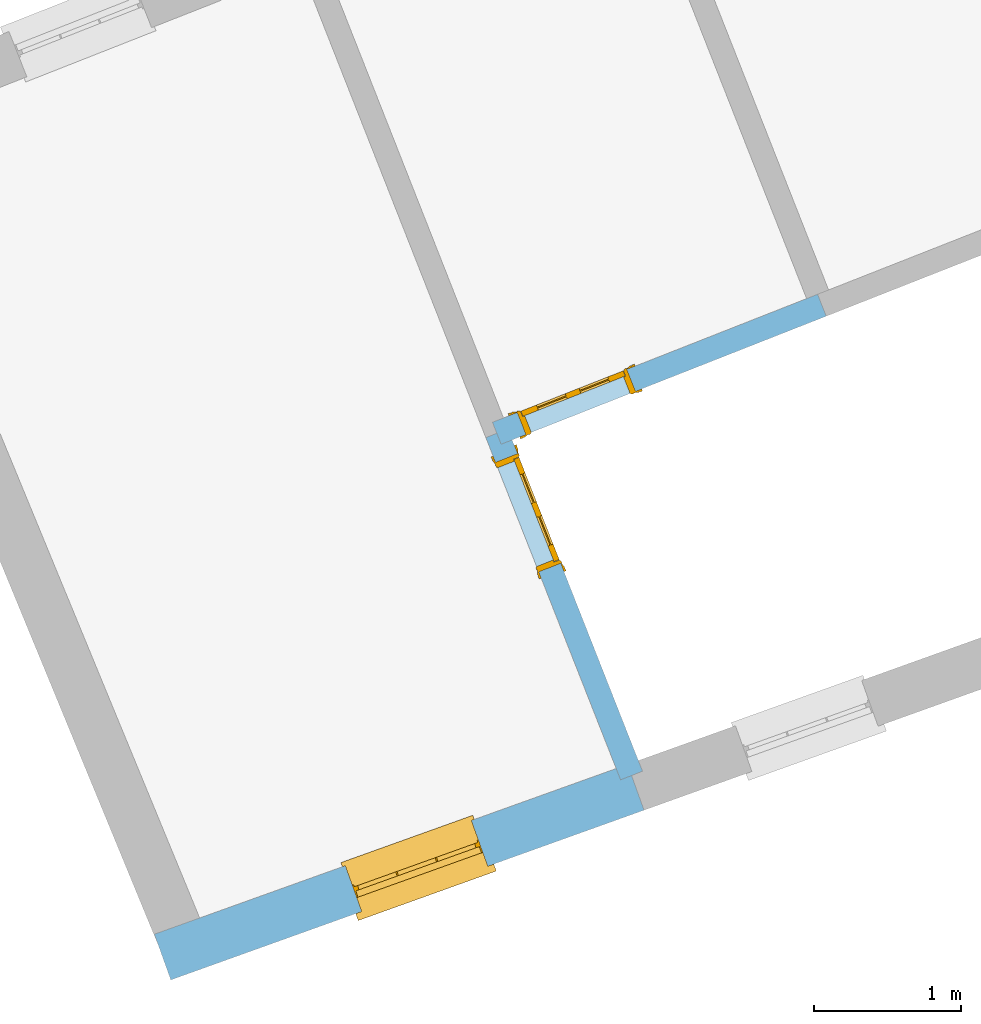
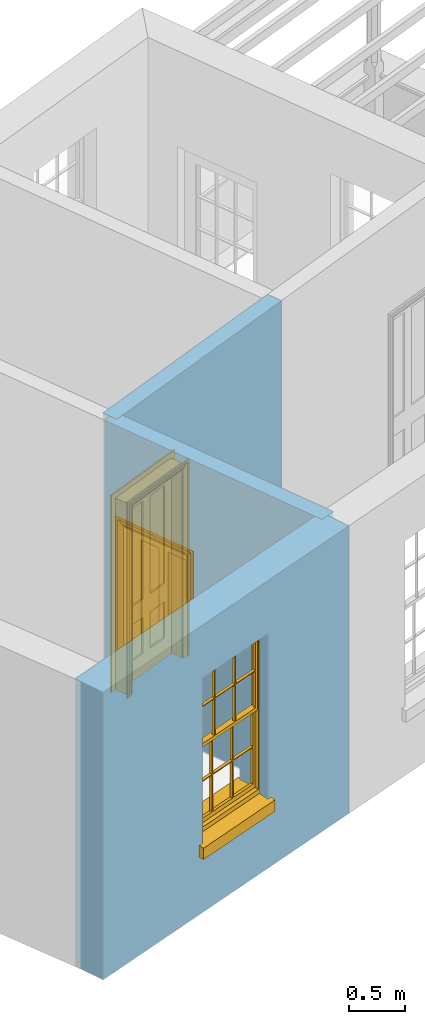
# One storey, part 2 of 8: 2 doors, 1 window, 3 openings, plus 3 elements that do not belong to this part.
"""IFC2X3 building model written with IfcOpenShell, lengths in metres."""

from ifc_helpers import new_model, si_unit, frame, origin, place, context, subcontext, project, spatial, polyline, outline, extrude, faceted_brep, material, layer, layer_set, layer_usage, element, fill, save


model = new_model("IFC2X3")

# Units and contexts
model_context = context("Model", 3, world=origin())
body_context = subcontext(model_context, "Body", "Model", "MODEL_VIEW")
ifc_project = project(units=[si_unit("PLANEANGLEUNIT", "RADIAN"), si_unit("MASSUNIT", "GRAM", prefix="KILO"), si_unit("FORCEUNIT", "NEWTON", prefix="KILO"), si_unit("LENGTHUNIT", "METRE")], contexts=[model_context])

# Site, building, storey
site_placement = place(None, origin())
site = spatial("IfcSite", under=ifc_project, at=site_placement, CompositionType="ELEMENT")
building_placement = place(None, origin())
building = spatial("IfcBuilding", under=site, at=building_placement, Name="Building plot-4", CompositionType="ELEMENT")
storey_placement = place(None, frame((0.0, 0.0, 9.45)))
storey = spatial("IfcBuildingStorey", under=building, at=storey_placement, Name="Floor 2", CompositionType="ELEMENT", Elevation=9.45)

# Wall, opening, window
ifc_material_1 = material(Name="Masonry")
ifc_layer_1 = layer(ifc_material_1, 0.33, ventilated=False)
ifc_layer_set_1 = layer_set([ifc_layer_1], Name="My Wall")
ifc_layer_usage_1 = layer_usage(ifc_layer_set_1, "AXIS2", "NEGATIVE", 0.08)
wall_1_placement = place(storey_placement, origin())
wall_1 = element("IfcWallStandardCase", 1, at=wall_1_placement, inside=storey, material=ifc_layer_usage_1, Name="exterior", context=body_context, shape_type="SweptSolid", body=[
    extrude(outline(polyline([(46.3816931332496, 45.3875319065881), (46.4931346698559, 45.0769183461649), (49.70423854185, 46.2289940933087), (49.5927970052436, 46.539607653732), (46.3816931332496, 45.3875319065881)])), origin(), (0.0, 0.0, 1.0), 3.15),
])
opening_1_placement = place(storey_placement, frame((0.0, 0.0, 0.75)))
opening_1 = element("IfcOpeningElement", 2, at=opening_1_placement, cuts=wall_1, Name="Opening", ObjectType="Opening", context=body_context, shape_type="SweptSolid", body=[
    extrude(outline(polyline([(47.7880730454297, 45.5415146831305), (48.6446134696272, 45.8488231628631), (48.5331719330208, 46.1594367232864), (47.6766315088233, 45.8521282435537), (47.7880730454297, 45.5415146831305)])), origin(), (0.0, 0.0, 1.0), 1.82),
])
window_placement = place(storey_placement, frame((47.7036476389097, 45.7768279864814, 0.75), z_axis=(0.0, 0.0, 1.0), x_axis=(0.856540424197469, 0.307308479732683, 0.0)))
window = element("IfcWindow", 3, at=window_placement, inside=storey, Name="bedroom outside window", OverallHeight=1.82, OverallWidth=0.91, context=body_context, shape_type="Brep", held_by="IfcProductRepresentation", body=[
    faceted_brep([(0.033125, -0.105, 0.975209), (0.01, -0.105, 0.975209), (0.033125, -0.105, 1.376042), (0.876875, -0.105, 0.975209), (0.876875, -0.105, 1.376042), (0.9, -0.105, 0.975209), (0.876875, -0.105, 1.386042), (0.876875, -0.105, 1.786875), (0.9, -0.105, 1.81), (0.033125, -0.105, 1.786875), (0.033125, -0.105, 1.386042), (0.01, -0.105, 1.81), (0.876875, -0.135, 1.376042), (0.876875, -0.135, 0.975209), (0.9, -0.135, 0.937083), (0.033125, -0.135, 1.786875), (0.01, -0.135, 1.81), (0.033125, -0.135, 1.386042), (0.01, -0.135, 0.937083), (0.033125, -0.135, 0.975209), (0.033125, -0.135, 1.376042), (0.876875, -0.135, 1.786875), (0.876875, -0.135, 1.386042), (0.9, -0.135, 1.81), (0.033125, -0.105, 0.937083), (0.01, -0.105, 0.937083), (0.033125, -0.105, 0.53625), (0.876875, -0.105, 0.937083), (0.876875, -0.105, 0.53625), (0.9, -0.105, 0.937083), (0.876875, -0.105, 0.52625), (0.876875, -0.105, 0.125417), (0.9, -0.105, 0.077167), (0.033125, -0.105, 0.125417), (0.033125, -0.105, 0.52625), (0.01, -0.105, 0.077167), (-0.0425, -0.25, 0.01), (-0.0425, -0.3, 0.001667), (0.0, -0.25, 0.01), (0.9525, -0.25, 0.01), (0.91, -0.25, 0.01), (0.9525, -0.3, 0.001667), (-0.02, 0.08, 0.077167), (0.0, 0.08, 0.077167), (-0.02, 0.11, 0.077167), (0.0, -0.06, 0.077167), (0.01, -0.06, 0.077167), (0.91, -0.06, 0.077167), (0.91, 0.08, 0.077167), (0.9, -0.06, 0.077167), (0.93, 0.08, 0.077167), (0.93, 0.11, 0.077167), (0.01, -0.075, 0.975209), (0.9, -0.075, 0.975209), (0.876875, -0.075, 0.125417), (0.876875, -0.075, 0.52625), (0.9, -0.075, 0.077167), (0.876875, -0.075, 0.53625), (0.876875, -0.075, 0.937083), (0.033125, -0.075, 0.125417), (0.01, -0.075, 0.077167), (0.033125, -0.075, 0.52625), (0.033125, -0.075, 0.937083), (0.033125, -0.075, 0.53625), (-0.02, 0.08, 0.052167), (-0.02, 0.11, 0.052167), (0.93, 0.11, 0.052167), (0.93, 0.08, 0.052167), (0.91, 0.08, 0.052167), (0.0, 0.08, 0.052167), (0.91, -0.15, 0.026667), (0.0, -0.15, 0.026667), (-0.0425, -0.3, -0.123333), (0.9525, -0.3, -0.123333), (-0.0425, -0.25, -0.123333), (0.9525, -0.25, -0.123333), (0.01, -0.06, 1.81), (0.9, -0.06, 1.81), (0.0, -0.06, 1.82), (0.91, -0.06, 1.82), (0.01, -0.15, 0.077167), (0.9, -0.15, 0.077167), (0.592292, -0.105, 0.125417), (0.592292, -0.075, 0.125417), (0.317708, -0.075, 0.125417), (0.317708, -0.105, 0.125417), (0.592292, -0.105, 0.53625), (0.317708, -0.105, 0.53625), (0.317708, -0.105, 0.52625), (0.592292, -0.105, 0.52625), (0.592292, -0.075, 0.53625), (0.317708, -0.075, 0.53625), (0.592292, -0.135, 1.386042), (0.592292, -0.105, 1.386042), (0.317708, -0.105, 1.386042), (0.317708, -0.135, 1.386042), (0.317708, -0.135, 1.376042), (0.592292, -0.135, 1.376042), (0.317708, -0.105, 1.376042), (0.592292, -0.105, 1.376042), (0.602292, -0.135, 1.376042), (0.592292, -0.135, 0.975209), (0.602292, -0.135, 0.975209), (0.602292, -0.105, 0.975209), (0.592292, -0.105, 0.975209), (0.602292, -0.105, 1.376042), (0.602292, -0.075, 0.53625), (0.602292, -0.105, 0.53625), (0.317708, -0.075, 0.52625), (0.307708, -0.075, 0.125417), (0.307708, -0.075, 0.52625), (0.602292, -0.075, 0.52625), (0.602292, -0.075, 0.125417), (0.592292, -0.075, 0.52625), (0.307708, -0.075, 0.53625), (0.317708, -0.075, 0.937083), (0.307708, -0.075, 0.937083), (0.602292, -0.075, 0.937083), (0.592292, -0.075, 0.937083), (0.307708, -0.105, 0.52625), (0.307708, -0.105, 0.125417), (0.307708, -0.105, 0.53625), (0.307708, -0.105, 0.937083), (0.592292, -0.105, 0.937083), (0.317708, -0.105, 0.937083), (0.602292, -0.105, 0.937083), (0.602292, -0.105, 0.52625), (0.602292, -0.105, 0.125417), (0.307708, -0.135, 1.386042), (0.307708, -0.135, 1.376042), (0.307708, -0.135, 0.975209), (0.317708, -0.135, 0.975209), (0.317708, -0.135, 1.786875), (0.307708, -0.135, 1.786875), (0.602292, -0.135, 1.786875), (0.592292, -0.135, 1.786875), (0.602292, -0.135, 1.386042), (0.602292, -0.105, 1.386042), (0.307708, -0.105, 1.386042), (0.307708, -0.105, 1.786875), (0.317708, -0.105, 1.786875), (0.592292, -0.105, 1.786875), (0.602292, -0.105, 1.786875), (0.307708, -0.105, 1.376042), (0.317708, -0.105, 0.975209), (0.307708, -0.105, 0.975209), (0.91, -0.15, 1.82), (0.9, -0.15, 1.81), (0.01, -0.15, 1.81), (0.0, -0.15, 1.82), (0.91, -0.25, 0.0), (0.0, -0.25, 0.0), (0.91, 0.08, 0.0), (0.0, 0.08, 0.0)], [[[0, 1, 2]], [[3, 4, 5]], [[6, 7, 8]], [[9, 10, 11]], [[12, 13, 14]], [[15, 16, 17]], [[18, 19, 20]], [[21, 22, 23]], [[24, 25, 26]], [[27, 28, 29]], [[30, 31, 32]], [[33, 34, 35]], [[14, 27, 29]], [[25, 24, 18]], [[36, 37, 38]], [[39, 40, 41]], [[42, 43, 44]], [[45, 46, 43]], [[47, 48, 49]], [[50, 51, 48]], [[1, 0, 52]], [[5, 53, 3]], [[54, 55, 56]], [[57, 58, 53]], [[59, 60, 61]], [[62, 63, 52]], [[48, 43, 46, 49]], [[51, 44, 43, 48]], [[64, 42, 44, 65]], [[65, 44, 51, 66]], [[66, 51, 50, 67]], [[65, 66, 68, 69]], [[60, 56, 49, 46]], [[70, 71, 38, 40]], [[37, 41, 40, 38]], [[37, 72, 73, 41]], [[74, 75, 73, 72]], [[8, 11, 76, 77]], [[76, 78, 79, 77]], [[32, 35, 80, 81]], [[81, 80, 71, 70]], [[82, 83, 84, 85]], [[86, 87, 88, 89]], [[86, 90, 91, 87]], [[92, 93, 94, 95]], [[92, 95, 96, 97]], [[96, 98, 99, 97]], [[100, 97, 101, 102]], [[103, 104, 99, 105]], [[97, 99, 104, 101]], [[102, 103, 105, 100]], [[28, 57, 106, 107]], [[108, 84, 109, 110]], [[111, 112, 83, 113]], [[114, 110, 61, 63]], [[90, 113, 108, 91]], [[115, 91, 114, 116]], [[117, 106, 90, 118]], [[111, 106, 57, 55]], [[119, 110, 109, 120]], [[34, 61, 110, 119]], [[89, 113, 83, 82]], [[88, 108, 113, 89]], [[85, 84, 108, 88]], [[121, 114, 63, 26]], [[122, 116, 114, 121]], [[123, 118, 90, 86]], [[87, 91, 115, 124]], [[107, 106, 117, 125]], [[126, 111, 55, 30]], [[127, 112, 111, 126]], [[126, 30, 28, 107]], [[88, 119, 120, 85]], [[126, 89, 82, 127]], [[125, 123, 86, 107]], [[121, 26, 34, 119]], [[124, 122, 121, 87]], [[128, 17, 20, 129]], [[96, 129, 130, 131]], [[132, 133, 128, 95]], [[134, 135, 92, 136]], [[100, 12, 22, 136]], [[137, 6, 4, 105]], [[94, 138, 139, 140]], [[137, 93, 141, 142]], [[99, 98, 94, 93]], [[143, 2, 10, 138]], [[144, 145, 143, 98]], [[129, 143, 145, 130]], [[20, 2, 143, 129]], [[131, 144, 98, 96]], [[128, 138, 10, 17]], [[133, 139, 138, 128]], [[135, 141, 93, 92]], [[95, 94, 140, 132]], [[22, 6, 137, 136]], [[136, 137, 142, 134]], [[100, 105, 4, 12]], [[107, 86, 89, 126]], [[106, 111, 113, 90]], [[91, 108, 110, 114]], [[87, 121, 119, 88]], [[97, 100, 136, 92]], [[129, 96, 95, 128]], [[98, 143, 138, 94]], [[105, 99, 93, 137]], [[131, 101, 104, 144]], [[124, 115, 118, 123]], [[132, 140, 141, 135]], [[120, 109, 59, 33]], [[15, 9, 139, 133]], [[134, 142, 7, 21]], [[31, 54, 112, 127]], [[36, 74, 72, 37]], [[39, 41, 73, 75]], [[18, 14, 101, 131]], [[23, 16, 132, 135]], [[83, 56, 60, 84]], [[52, 53, 118, 115]], [[53, 52, 144, 104]], [[11, 8, 141, 140]], [[14, 18, 124, 123]], [[2, 1, 11, 10]], [[8, 5, 4, 6]], [[57, 53, 56, 55]], [[60, 52, 63, 61]], [[26, 25, 35, 34]], [[32, 29, 28, 30]], [[14, 23, 22, 12]], [[18, 20, 17, 16]], [[19, 0, 2, 20]], [[17, 10, 9, 15]], [[12, 4, 3, 13]], [[21, 7, 6, 22]], [[27, 58, 57, 28]], [[30, 55, 54, 31]], [[33, 59, 61, 34]], [[26, 63, 62, 24]], [[5, 8, 77, 53]], [[76, 11, 1, 52]], [[46, 45, 78, 76]], [[49, 77, 79, 47]], [[70, 146, 147, 81]], [[71, 80, 148, 149]], [[19, 130, 145, 0]], [[102, 13, 3, 103]], [[116, 122, 24, 62]], [[29, 32, 81, 14]], [[80, 35, 25, 18]], [[60, 46, 76, 52]], [[77, 49, 56, 53]], [[23, 14, 81, 147]], [[16, 148, 80, 18]], [[35, 85, 120]], [[120, 33, 35]], [[127, 82, 32]], [[32, 31, 127]], [[32, 82, 85, 35]], [[102, 101, 14]], [[14, 13, 102]], [[18, 131, 130]], [[130, 19, 18]], [[134, 21, 23]], [[23, 135, 134]], [[16, 15, 133]], [[133, 132, 16]], [[11, 140, 139]], [[139, 9, 11]], [[142, 141, 8]], [[8, 7, 142]], [[23, 147, 148, 16]], [[146, 149, 148, 147]], [[52, 115, 116]], [[116, 62, 52]], [[118, 53, 117]], [[58, 117, 53]], [[27, 125, 117, 58]], [[56, 83, 112]], [[112, 54, 56]], [[109, 84, 60]], [[60, 59, 109]], [[125, 27, 14]], [[14, 123, 125]], [[122, 124, 18]], [[18, 24, 122]], [[145, 144, 52]], [[52, 0, 145]], [[103, 3, 53]], [[53, 104, 103]], [[79, 78, 149, 146]], [[78, 45, 71, 149]], [[146, 70, 47, 79]], [[150, 75, 74, 151]], [[68, 66, 67]], [[48, 68, 67, 50]], [[69, 64, 65]], [[42, 64, 69, 43]], [[69, 68, 152, 153]], [[70, 68, 48, 47]], [[150, 152, 68, 70]], [[43, 69, 71, 45]], [[69, 153, 151, 71]], [[152, 150, 151, 153]], [[38, 151, 74, 36]], [[71, 151, 38]], [[39, 75, 150, 40]], [[40, 150, 70]]]),
])
fill(opening_1, window)

# Wall, opening, door
ifc_material_2 = material(Name="Masonry")
ifc_layer_2 = layer(ifc_material_2, 0.16, ventilated=False)
ifc_layer_set_2 = layer_set([ifc_layer_2], Name="My Wall")
ifc_layer_usage_2 = layer_usage(ifc_layer_set_2, "AXIS2", "NEGATIVE", 0.08)
wall_2_placement = place(storey_placement, origin())
wall_2 = element("IfcWallStandardCase", 4, at=wall_2_placement, inside=storey, material=ifc_layer_usage_2, Name="interior", context=body_context, shape_type="SweptSolid", body=[
    extrude(outline(polyline([(48.675963659778, 48.860958817468), (48.7345922073266, 48.7120874185616), (50.9405049863652, 49.5808201852595), (50.8818764388166, 49.7296915841659), (48.675963659778, 48.860958817468)])), origin(), (0.0, 0.0, 1.0), 3.15),
])
opening_2_placement = place(storey_placement, frame((0.0, 0.0, 0.0199999999999996)))
opening_2 = element("IfcOpeningElement", 5, at=opening_2_placement, cuts=wall_2, Name="Opening", ObjectType="Opening", context=body_context, shape_type="SweptSolid", body=[
    extrude(outline(polyline([(48.9020725310963, 48.7780445345539), (49.646429525628, 49.0711872722973), (49.5878009780793, 49.2200586712036), (48.8434439835476, 48.9269159334602), (48.9020725310963, 48.7780445345539)])), origin(), (0.0, 0.0, 1.0), 2.1),
])
door_1_placement = place(storey_placement, frame((48.8727582573219, 48.8524802340071, 0.0199999999999996), z_axis=(0.0, 0.0, 1.0), x_axis=(0.744356994531735, 0.293142737743381, 0.0)))
door_1 = element("IfcDoor", 6, at=door_1_placement, inside=storey, Name="toilet inside door", OverallHeight=2.1, OverallWidth=0.8, context=body_context, shape_type="Brep", held_by="IfcProductRepresentation", body=[
    faceted_brep([(0.773, 0.08, 1.895), (0.66, 0.08, 1.895), (0.66, 0.08, 2.073), (0.773, 0.08, 2.073), (0.773, 0.08, 0.82), (0.66, 0.08, 0.82), (0.45, 0.08, 1.895), (0.45, 0.08, 2.073), (0.773, 0.08, 0.62), (0.66, 0.08, 0.62), (0.66, 0.065, 0.82), (0.66, 0.065, 1.895), (0.45, 0.065, 1.895), (0.35, 0.08, 1.895), (0.35, 0.08, 2.073), (0.773, 0.08, 0.225), (0.66, 0.08, 0.225), (0.45, 0.08, 0.62), (0.45, 0.08, 0.82), (0.45, 0.065, 0.82), (0.35, 0.08, 0.82), (0.14, 0.08, 2.073), (0.14, 0.08, 1.895), (0.773, 0.08, 0.0), (0.66, 0.08, 0.0), (0.66, 0.065, 0.225), (0.66, 0.065, 0.62), (0.45, 0.065, 0.62), (0.35, 0.08, 0.62), (0.35, 0.065, 0.82), (0.35, 0.065, 1.895), (0.14, 0.065, 1.895), (0.027, 0.08, 2.073), (0.027, 0.08, 1.895), (0.773, 0.042, 0.0), (0.66, 0.042, 0.0), (0.45, 0.08, 0.0), (0.45, 0.08, 0.225), (0.45, 0.065, 0.225), (0.35, 0.08, 0.225), (0.14, 0.08, 0.82), (0.14, 0.08, 0.62), (0.14, 0.065, 0.82), (0.027, 0.08, 0.82), (0.773, 0.042, 0.225), (0.66, 0.042, 0.225), (0.45, 0.042, 0.0), (0.35, 0.08, 0.0), (0.35, 0.065, 0.225), (0.35, 0.065, 0.62), (0.14, 0.065, 0.62), (0.027, 0.08, 0.62), (0.773, 0.042, 0.62), (0.66, 0.042, 0.62), (0.45, 0.042, 0.225), (0.35, 0.042, 0.0), (0.14, 0.08, 0.225), (0.14, 0.08, 0.0), (0.14, 0.065, 0.225), (0.027, 0.08, 0.225), (0.773, 0.042, 0.82), (0.66, 0.042, 0.82), (0.66, 0.057, 0.62), (0.66, 0.057, 0.225), (0.45, 0.057, 0.225), (0.35, 0.042, 0.225), (0.14, 0.042, 0.0), (0.027, 0.08, 0.0), (0.773, 0.042, 1.895), (0.66, 0.042, 1.895), (0.45, 0.042, 0.62), (0.45, 0.042, 0.82), (0.45, 0.057, 0.62), (0.35, 0.042, 0.62), (0.14, 0.042, 0.225), (0.027, 0.042, 0.0), (0.773, 0.042, 2.073), (0.66, 0.042, 2.073), (0.66, 0.057, 1.895), (0.66, 0.057, 0.82), (0.45, 0.057, 0.82), (0.35, 0.042, 0.82), (0.35, 0.057, 0.62), (0.35, 0.057, 0.225), (0.14, 0.057, 0.225), (0.027, 0.042, 0.225), (0.45, 0.042, 1.895), (0.45, 0.042, 2.073), (0.45, 0.057, 1.895), (0.35, 0.042, 1.895), (0.14, 0.042, 0.82), (0.14, 0.042, 0.62), (0.14, 0.057, 0.62), (0.027, 0.042, 0.62), (0.35, 0.042, 2.073), (0.35, 0.057, 1.895), (0.35, 0.057, 0.82), (0.14, 0.057, 0.82), (0.027, 0.042, 0.82), (0.14, 0.042, 2.073), (0.14, 0.042, 1.895), (0.14, 0.057, 1.895), (0.027, 0.042, 1.895), (0.027, 0.042, 2.073), (0.02, 0.085, 0.0), (0.005, 0.09, 0.0), (0.005, 0.09, 2.095), (0.02, 0.085, 2.08), (0.02, 0.08, 0.0), (0.0, 0.085, 0.0), (0.0, 0.085, 2.1), (0.795, 0.09, 2.095), (0.78, 0.085, 2.08), (0.02, 0.08, 2.08), (0.0, 0.08, 0.0), (-0.032, 0.095, 0.0), (-0.032, 0.095, 2.132), (0.8, 0.085, 2.1), (0.795, 0.09, 0.0), (0.78, 0.085, 0.0), (0.78, 0.08, 2.08), (0.04, 0.04, 0.0), (0.025, 0.04, 0.0), (0.025, 0.04, 2.075), (0.04, 0.04, 2.06), (-0.04, 0.09, 0.0), (-0.04, 0.09, 2.14), (0.832, 0.095, 2.132), (0.8, 0.085, 0.0), (0.78, 0.08, 0.0), (0.8, 0.08, 0.0), (0.86, 0.08, 0.0), (0.86, 0.08, 2.16), (0.8, 0.08, 2.1), (-0.06, 0.08, 2.16), (0.0, 0.08, 2.1), (-0.06, 0.08, 0.0), (-0.04, 0.095, 0.0), (-0.04, 0.095, 2.14), (0.84, 0.09, 2.14), (0.832, 0.095, 0.0), (0.84, 0.09, 0.0), (0.86, 0.095, 0.0), (0.86, 0.095, 2.16), (-0.06, 0.095, 2.16), (-0.06, 0.095, 0.0), (0.84, 0.095, 0.0), (0.84, 0.095, 2.14), (-0.025, -0.095, 0.0), (-0.025, -0.09, 0.0), (-0.025, -0.09, 2.125), (-0.025, -0.095, 2.125), (-0.017, -0.095, 0.0), (-0.017, -0.095, 2.117), (0.825, -0.09, 2.125), (0.825, -0.095, 2.125), (0.825, -0.095, 0.0), (0.845, -0.095, 0.0), (-0.045, -0.095, 2.145), (-0.045, -0.095, 0.0), (0.845, -0.095, 2.145), (0.015, -0.085, 0.0), (0.015, -0.085, 2.085), (0.817, -0.095, 2.117), (0.825, -0.09, 0.0), (0.845, -0.08, 0.0), (0.845, -0.08, 2.145), (-0.045, -0.08, 2.145), (-0.045, -0.08, 0.0), (0.02, -0.09, 0.0), (0.02, -0.09, 2.08), (0.785, -0.085, 2.085), (0.817, -0.095, 0.0), (0.8, -0.08, 0.0), (0.8, -0.08, 2.1), (0.0, -0.08, 2.1), (0.0, -0.08, 0.0), (0.035, -0.085, 0.0), (0.035, -0.085, 2.065), (0.78, -0.09, 2.08), (0.785, -0.085, 0.0), (0.775, 0.04, 2.075), (0.76, 0.04, 2.06), (0.035, -0.08, 2.065), (0.035, -0.08, 0.0), (0.765, -0.085, 2.065), (0.78, -0.09, 0.0), (0.765, -0.08, 0.0), (0.765, -0.08, 2.065), (0.765, -0.085, 0.0), (0.04, -0.08, 2.06), (0.04, -0.08, 0.0), (0.76, -0.08, 2.06), (0.76, -0.08, 0.0), (0.76, 0.04, 0.0), (0.775, 0.04, 0.0), (0.025, 0.08, 0.0), (0.025, 0.08, 2.075), (0.775, 0.08, 0.0), (0.775, 0.08, 2.075)], [[[0, 1, 2, 3]], [[1, 0, 4, 5]], [[1, 6, 7, 2]], [[8, 9, 5, 4]], [[1, 5, 10, 11]], [[6, 1, 11, 12]], [[6, 13, 14, 7]], [[15, 16, 9, 8]], [[9, 17, 18, 5]], [[5, 18, 19, 10]], [[10, 19, 12, 11]], [[18, 6, 12, 19]], [[18, 20, 13, 6]], [[21, 14, 13, 22]], [[23, 24, 16, 15]], [[9, 16, 25, 26]], [[17, 9, 26, 27]], [[17, 28, 20, 18]], [[13, 20, 29, 30]], [[22, 13, 30, 31]], [[32, 21, 22, 33]], [[34, 35, 24, 23]], [[24, 36, 37, 16]], [[16, 37, 38, 25]], [[25, 38, 27, 26]], [[37, 17, 27, 38]], [[37, 39, 28, 17]], [[40, 20, 28, 41]], [[20, 40, 42, 29]], [[31, 30, 29, 42]], [[40, 22, 31, 42]], [[33, 22, 40, 43]], [[35, 34, 44, 45]], [[35, 46, 36, 24]], [[36, 47, 39, 37]], [[28, 39, 48, 49]], [[41, 28, 49, 50]], [[43, 40, 41, 51]], [[45, 44, 52, 53]], [[46, 35, 45, 54]], [[46, 55, 47, 36]], [[56, 39, 47, 57]], [[39, 56, 58, 48]], [[50, 49, 48, 58]], [[56, 41, 50, 58]], [[51, 41, 56, 59]], [[53, 52, 60, 61]], [[45, 53, 62, 63]], [[54, 45, 63, 64]], [[55, 46, 54, 65]], [[55, 66, 57, 47]], [[59, 56, 57, 67]], [[61, 60, 68, 69]], [[70, 53, 61, 71]], [[53, 70, 72, 62]], [[72, 64, 63, 62]], [[70, 54, 64, 72]], [[65, 54, 70, 73]], [[65, 74, 66, 55]], [[67, 57, 66, 75]], [[69, 68, 76, 77]], [[61, 69, 78, 79]], [[71, 61, 79, 80]], [[73, 70, 71, 81]], [[65, 73, 82, 83]], [[74, 65, 83, 84]], [[74, 85, 75, 66]], [[86, 69, 77, 87]], [[69, 86, 88, 78]], [[88, 80, 79, 78]], [[86, 71, 80, 88]], [[81, 71, 86, 89]], [[73, 81, 90, 91]], [[73, 91, 92, 82]], [[83, 82, 92, 84]], [[91, 74, 84, 92]], [[91, 93, 85, 74]], [[89, 86, 87, 94]], [[81, 89, 95, 96]], [[90, 81, 96, 97]], [[90, 98, 93, 91]], [[94, 99, 100, 89]], [[89, 100, 101, 95]], [[101, 97, 96, 95]], [[100, 90, 97, 101]], [[100, 102, 98, 90]], [[99, 103, 102, 100]], [[32, 103, 99, 21]], [[102, 103, 32, 33]], [[98, 102, 33, 43]], [[21, 99, 94, 14]], [[94, 87, 7, 14]], [[7, 87, 77, 2]], [[76, 3, 2, 77]], [[43, 51, 93, 98]], [[51, 59, 85, 93]], [[67, 75, 85, 59]], [[34, 23, 15, 44]], [[44, 15, 8, 52]], [[52, 8, 4, 60]], [[0, 68, 60, 4]], [[0, 3, 76, 68]], [[104, 105, 106, 107]], [[104, 108, 109, 105]], [[105, 109, 110, 106]], [[107, 106, 111, 112]], [[107, 113, 108, 104]], [[114, 109, 108]], [[109, 115, 116, 110]], [[106, 110, 117, 111]], [[112, 111, 118, 119]], [[113, 107, 112, 120]], [[121, 122, 123, 124]], [[115, 109, 114, 125]], [[115, 125, 126, 116]], [[110, 116, 127, 117]], [[111, 117, 128, 118]], [[118, 128, 129, 119]], [[120, 112, 119, 129]], [[130, 129, 128]], [[130, 131, 132, 133]], [[133, 132, 134, 135]], [[135, 134, 136, 114]], [[136, 125, 114]], [[125, 137, 138, 126]], [[116, 126, 139, 127]], [[117, 127, 140, 128]], [[141, 130, 128, 140]], [[131, 130, 141]], [[131, 142, 143, 132]], [[132, 143, 144, 134]], [[134, 144, 145, 136]], [[137, 125, 136, 145]], [[143, 142, 146]], [[143, 146, 147]], [[137, 145, 144]], [[143, 147, 138]], [[138, 137, 144]], [[143, 138, 144]], [[126, 138, 147, 139]], [[127, 139, 141, 140]], [[142, 131, 141, 146]], [[139, 147, 146, 141]], [[148, 149, 150, 151]], [[149, 152, 153, 150]], [[151, 150, 154, 155]], [[155, 156, 157]], [[158, 159, 148]], [[158, 148, 151]], [[155, 157, 160]], [[158, 151, 155]], [[155, 160, 158]], [[152, 161, 162, 153]], [[150, 153, 163, 154]], [[155, 154, 164, 156]], [[156, 164, 165, 157]], [[157, 165, 166, 160]], [[160, 166, 167, 158]], [[158, 167, 168, 159]], [[161, 169, 170, 162]], [[153, 162, 171, 163]], [[154, 163, 172, 164]], [[165, 164, 173]], [[165, 173, 174, 166]], [[166, 174, 175, 167]], [[167, 175, 176, 168]], [[169, 177, 178, 170]], [[162, 170, 179, 171]], [[163, 171, 180, 172]], [[172, 180, 173, 164]], [[124, 123, 181, 182]], [[183, 178, 177, 184]], [[170, 178, 185, 179]], [[171, 179, 186, 180]], [[187, 173, 180]], [[185, 188, 187, 189]], [[188, 185, 178, 183]], [[179, 185, 189, 186]], [[189, 187, 180, 186]], [[190, 183, 184, 191]], [[192, 188, 183, 190]], [[191, 184, 122, 121]], [[124, 190, 191, 121]], [[193, 187, 188, 192]], [[182, 192, 190, 124]], [[184, 176, 122]], [[194, 195, 187, 193]], [[192, 182, 194, 193]], [[161, 176, 184]], [[114, 108, 122, 176]], [[173, 187, 195]], [[152, 149, 176, 161]], [[169, 161, 184, 177]], [[196, 122, 108]], [[176, 175, 135, 114]], [[173, 195, 129, 130]], [[176, 149, 168]], [[123, 122, 196, 197]], [[196, 108, 113, 197]], [[175, 174, 133, 135]], [[198, 129, 195]], [[133, 174, 173, 130]], [[159, 168, 149, 148]], [[181, 123, 197, 199]], [[197, 113, 120, 199]], [[199, 120, 129, 198]], [[195, 181, 199, 198]], [[195, 194, 182, 181]]]),
])
fill(opening_2, door_1)

wall_3_placement = place(storey_placement, origin())
wall_3 = element("IfcWallStandardCase", 7, at=wall_3_placement, inside=storey, material=ifc_layer_usage_2, Name="interior", context=body_context, shape_type="SweptSolid", body=[
    extrude(outline(polyline([(48.7797136330055, 48.8158373917891), (48.6308422340991, 48.7572088442405), (49.5453774358768, 46.4349931228854), (49.6942488347832, 46.493621670434), (48.7797136330055, 48.8158373917891)])), origin(), (0.0, 0.0, 1.0), 3.15),
])
opening_3_placement = place(storey_placement, frame((0.0, 0.0, 0.0199999999999996)))
opening_3 = element("IfcOpeningElement", 8, at=opening_3_placement, cuts=wall_3, Name="Opening", ObjectType="Opening", context=body_context, shape_type="SweptSolid", body=[
    extrude(outline(polyline([(48.6967993500914, 48.5897285204708), (48.9899420878348, 47.8453715259391), (49.1388134867411, 47.9040000734878), (48.8456707489977, 48.6483570680195), (48.6967993500914, 48.5897285204708)])), origin(), (0.0, 0.0, 1.0), 2.1),
])
door_2_placement = place(storey_placement, frame((48.7712350495446, 48.6190427942452, 0.0199999999999996), z_axis=(0.0, 0.0, 1.0), x_axis=(0.293142737743374, -0.744356994531742, 0.0)))
door_2 = element("IfcDoor", 9, at=door_2_placement, inside=storey, Name="bedroom inside door", OverallHeight=2.1, OverallWidth=0.8, context=body_context, shape_type="Brep", held_by="IfcProductRepresentation", body=[
    faceted_brep([(0.773, 0.08, 1.895), (0.66, 0.08, 1.895), (0.66, 0.08, 2.073), (0.773, 0.08, 2.073), (0.773, 0.08, 0.82), (0.66, 0.08, 0.82), (0.45, 0.08, 1.895), (0.45, 0.08, 2.073), (0.773, 0.08, 0.62), (0.66, 0.08, 0.62), (0.66, 0.065, 0.82), (0.66, 0.065, 1.895), (0.45, 0.065, 1.895), (0.35, 0.08, 1.895), (0.35, 0.08, 2.073), (0.773, 0.08, 0.225), (0.66, 0.08, 0.225), (0.45, 0.08, 0.62), (0.45, 0.08, 0.82), (0.45, 0.065, 0.82), (0.35, 0.08, 0.82), (0.14, 0.08, 2.073), (0.14, 0.08, 1.895), (0.773, 0.08, 0.0), (0.66, 0.08, 0.0), (0.66, 0.065, 0.225), (0.66, 0.065, 0.62), (0.45, 0.065, 0.62), (0.35, 0.08, 0.62), (0.35, 0.065, 0.82), (0.35, 0.065, 1.895), (0.14, 0.065, 1.895), (0.027, 0.08, 2.073), (0.027, 0.08, 1.895), (0.773, 0.042, 0.0), (0.66, 0.042, 0.0), (0.45, 0.08, 0.0), (0.45, 0.08, 0.225), (0.45, 0.065, 0.225), (0.35, 0.08, 0.225), (0.14, 0.08, 0.82), (0.14, 0.08, 0.62), (0.14, 0.065, 0.82), (0.027, 0.08, 0.82), (0.773, 0.042, 0.225), (0.66, 0.042, 0.225), (0.45, 0.042, 0.0), (0.35, 0.08, 0.0), (0.35, 0.065, 0.225), (0.35, 0.065, 0.62), (0.14, 0.065, 0.62), (0.027, 0.08, 0.62), (0.773, 0.042, 0.62), (0.66, 0.042, 0.62), (0.45, 0.042, 0.225), (0.35, 0.042, 0.0), (0.14, 0.08, 0.225), (0.14, 0.08, 0.0), (0.14, 0.065, 0.225), (0.027, 0.08, 0.225), (0.773, 0.042, 0.82), (0.66, 0.042, 0.82), (0.66, 0.057, 0.62), (0.66, 0.057, 0.225), (0.45, 0.057, 0.225), (0.35, 0.042, 0.225), (0.14, 0.042, 0.0), (0.027, 0.08, 0.0), (0.773, 0.042, 1.895), (0.66, 0.042, 1.895), (0.45, 0.042, 0.62), (0.45, 0.042, 0.82), (0.45, 0.057, 0.62), (0.35, 0.042, 0.62), (0.14, 0.042, 0.225), (0.027, 0.042, 0.0), (0.773, 0.042, 2.073), (0.66, 0.042, 2.073), (0.66, 0.057, 1.895), (0.66, 0.057, 0.82), (0.45, 0.057, 0.82), (0.35, 0.042, 0.82), (0.35, 0.057, 0.62), (0.35, 0.057, 0.225), (0.14, 0.057, 0.225), (0.027, 0.042, 0.225), (0.45, 0.042, 1.895), (0.45, 0.042, 2.073), (0.45, 0.057, 1.895), (0.35, 0.042, 1.895), (0.14, 0.042, 0.82), (0.14, 0.042, 0.62), (0.14, 0.057, 0.62), (0.027, 0.042, 0.62), (0.35, 0.042, 2.073), (0.35, 0.057, 1.895), (0.35, 0.057, 0.82), (0.14, 0.057, 0.82), (0.027, 0.042, 0.82), (0.14, 0.042, 2.073), (0.14, 0.042, 1.895), (0.14, 0.057, 1.895), (0.027, 0.042, 1.895), (0.027, 0.042, 2.073), (0.02, 0.085, 0.0), (0.005, 0.09, 0.0), (0.005, 0.09, 2.095), (0.02, 0.085, 2.08), (0.02, 0.08, 0.0), (0.0, 0.085, 0.0), (0.0, 0.085, 2.1), (0.795, 0.09, 2.095), (0.78, 0.085, 2.08), (0.02, 0.08, 2.08), (0.0, 0.08, 0.0), (-0.032, 0.095, 0.0), (-0.032, 0.095, 2.132), (0.8, 0.085, 2.1), (0.795, 0.09, 0.0), (0.78, 0.085, 0.0), (0.78, 0.08, 2.08), (0.04, 0.04, 0.0), (0.025, 0.04, 0.0), (0.025, 0.04, 2.075), (0.04, 0.04, 2.06), (-0.04, 0.09, 0.0), (-0.04, 0.09, 2.14), (0.832, 0.095, 2.132), (0.8, 0.085, 0.0), (0.78, 0.08, 0.0), (0.8, 0.08, 0.0), (0.86, 0.08, 0.0), (0.86, 0.08, 2.16), (0.8, 0.08, 2.1), (-0.06, 0.08, 2.16), (0.0, 0.08, 2.1), (-0.06, 0.08, 0.0), (-0.04, 0.095, 0.0), (-0.04, 0.095, 2.14), (0.84, 0.09, 2.14), (0.832, 0.095, 0.0), (0.84, 0.09, 0.0), (0.86, 0.095, 0.0), (0.86, 0.095, 2.16), (-0.06, 0.095, 2.16), (-0.06, 0.095, 0.0), (0.84, 0.095, 0.0), (0.84, 0.095, 2.14), (-0.025, -0.095, 0.0), (-0.025, -0.09, 0.0), (-0.025, -0.09, 2.125), (-0.025, -0.095, 2.125), (-0.017, -0.095, 0.0), (-0.017, -0.095, 2.117), (0.825, -0.09, 2.125), (0.825, -0.095, 2.125), (0.825, -0.095, 0.0), (0.845, -0.095, 0.0), (-0.045, -0.095, 2.145), (-0.045, -0.095, 0.0), (0.845, -0.095, 2.145), (0.015, -0.085, 0.0), (0.015, -0.085, 2.085), (0.817, -0.095, 2.117), (0.825, -0.09, 0.0), (0.845, -0.08, 0.0), (0.845, -0.08, 2.145), (-0.045, -0.08, 2.145), (-0.045, -0.08, 0.0), (0.02, -0.09, 0.0), (0.02, -0.09, 2.08), (0.785, -0.085, 2.085), (0.817, -0.095, 0.0), (0.8, -0.08, 0.0), (0.8, -0.08, 2.1), (0.0, -0.08, 2.1), (0.0, -0.08, 0.0), (0.035, -0.085, 0.0), (0.035, -0.085, 2.065), (0.78, -0.09, 2.08), (0.785, -0.085, 0.0), (0.775, 0.04, 2.075), (0.76, 0.04, 2.06), (0.035, -0.08, 2.065), (0.035, -0.08, 0.0), (0.765, -0.085, 2.065), (0.78, -0.09, 0.0), (0.765, -0.08, 0.0), (0.765, -0.08, 2.065), (0.765, -0.085, 0.0), (0.04, -0.08, 2.06), (0.04, -0.08, 0.0), (0.76, -0.08, 2.06), (0.76, -0.08, 0.0), (0.76, 0.04, 0.0), (0.775, 0.04, 0.0), (0.025, 0.08, 0.0), (0.025, 0.08, 2.075), (0.775, 0.08, 0.0), (0.775, 0.08, 2.075)], [[[0, 1, 2, 3]], [[1, 0, 4, 5]], [[1, 6, 7, 2]], [[8, 9, 5, 4]], [[1, 5, 10, 11]], [[6, 1, 11, 12]], [[6, 13, 14, 7]], [[15, 16, 9, 8]], [[9, 17, 18, 5]], [[5, 18, 19, 10]], [[10, 19, 12, 11]], [[18, 6, 12, 19]], [[18, 20, 13, 6]], [[21, 14, 13, 22]], [[23, 24, 16, 15]], [[9, 16, 25, 26]], [[17, 9, 26, 27]], [[17, 28, 20, 18]], [[13, 20, 29, 30]], [[22, 13, 30, 31]], [[32, 21, 22, 33]], [[34, 35, 24, 23]], [[24, 36, 37, 16]], [[16, 37, 38, 25]], [[25, 38, 27, 26]], [[37, 17, 27, 38]], [[37, 39, 28, 17]], [[40, 20, 28, 41]], [[20, 40, 42, 29]], [[31, 30, 29, 42]], [[40, 22, 31, 42]], [[33, 22, 40, 43]], [[35, 34, 44, 45]], [[35, 46, 36, 24]], [[36, 47, 39, 37]], [[28, 39, 48, 49]], [[41, 28, 49, 50]], [[43, 40, 41, 51]], [[45, 44, 52, 53]], [[46, 35, 45, 54]], [[46, 55, 47, 36]], [[56, 39, 47, 57]], [[39, 56, 58, 48]], [[50, 49, 48, 58]], [[56, 41, 50, 58]], [[51, 41, 56, 59]], [[53, 52, 60, 61]], [[45, 53, 62, 63]], [[54, 45, 63, 64]], [[55, 46, 54, 65]], [[55, 66, 57, 47]], [[59, 56, 57, 67]], [[61, 60, 68, 69]], [[70, 53, 61, 71]], [[53, 70, 72, 62]], [[72, 64, 63, 62]], [[70, 54, 64, 72]], [[65, 54, 70, 73]], [[65, 74, 66, 55]], [[67, 57, 66, 75]], [[69, 68, 76, 77]], [[61, 69, 78, 79]], [[71, 61, 79, 80]], [[73, 70, 71, 81]], [[65, 73, 82, 83]], [[74, 65, 83, 84]], [[74, 85, 75, 66]], [[86, 69, 77, 87]], [[69, 86, 88, 78]], [[88, 80, 79, 78]], [[86, 71, 80, 88]], [[81, 71, 86, 89]], [[73, 81, 90, 91]], [[73, 91, 92, 82]], [[83, 82, 92, 84]], [[91, 74, 84, 92]], [[91, 93, 85, 74]], [[89, 86, 87, 94]], [[81, 89, 95, 96]], [[90, 81, 96, 97]], [[90, 98, 93, 91]], [[94, 99, 100, 89]], [[89, 100, 101, 95]], [[101, 97, 96, 95]], [[100, 90, 97, 101]], [[100, 102, 98, 90]], [[99, 103, 102, 100]], [[32, 103, 99, 21]], [[102, 103, 32, 33]], [[98, 102, 33, 43]], [[21, 99, 94, 14]], [[94, 87, 7, 14]], [[7, 87, 77, 2]], [[76, 3, 2, 77]], [[43, 51, 93, 98]], [[51, 59, 85, 93]], [[67, 75, 85, 59]], [[34, 23, 15, 44]], [[44, 15, 8, 52]], [[52, 8, 4, 60]], [[0, 68, 60, 4]], [[0, 3, 76, 68]], [[104, 105, 106, 107]], [[104, 108, 109, 105]], [[105, 109, 110, 106]], [[107, 106, 111, 112]], [[107, 113, 108, 104]], [[114, 109, 108]], [[109, 115, 116, 110]], [[106, 110, 117, 111]], [[112, 111, 118, 119]], [[113, 107, 112, 120]], [[121, 122, 123, 124]], [[115, 109, 114, 125]], [[115, 125, 126, 116]], [[110, 116, 127, 117]], [[111, 117, 128, 118]], [[118, 128, 129, 119]], [[120, 112, 119, 129]], [[130, 129, 128]], [[130, 131, 132, 133]], [[133, 132, 134, 135]], [[135, 134, 136, 114]], [[136, 125, 114]], [[125, 137, 138, 126]], [[116, 126, 139, 127]], [[117, 127, 140, 128]], [[141, 130, 128, 140]], [[131, 130, 141]], [[131, 142, 143, 132]], [[132, 143, 144, 134]], [[134, 144, 145, 136]], [[137, 125, 136, 145]], [[143, 142, 146]], [[143, 146, 147]], [[137, 145, 144]], [[143, 147, 138]], [[138, 137, 144]], [[143, 138, 144]], [[126, 138, 147, 139]], [[127, 139, 141, 140]], [[142, 131, 141, 146]], [[139, 147, 146, 141]], [[148, 149, 150, 151]], [[149, 152, 153, 150]], [[151, 150, 154, 155]], [[155, 156, 157]], [[158, 159, 148]], [[158, 148, 151]], [[155, 157, 160]], [[158, 151, 155]], [[155, 160, 158]], [[152, 161, 162, 153]], [[150, 153, 163, 154]], [[155, 154, 164, 156]], [[156, 164, 165, 157]], [[157, 165, 166, 160]], [[160, 166, 167, 158]], [[158, 167, 168, 159]], [[161, 169, 170, 162]], [[153, 162, 171, 163]], [[154, 163, 172, 164]], [[165, 164, 173]], [[165, 173, 174, 166]], [[166, 174, 175, 167]], [[167, 175, 176, 168]], [[169, 177, 178, 170]], [[162, 170, 179, 171]], [[163, 171, 180, 172]], [[172, 180, 173, 164]], [[124, 123, 181, 182]], [[183, 178, 177, 184]], [[170, 178, 185, 179]], [[171, 179, 186, 180]], [[187, 173, 180]], [[185, 188, 187, 189]], [[188, 185, 178, 183]], [[179, 185, 189, 186]], [[189, 187, 180, 186]], [[190, 183, 184, 191]], [[192, 188, 183, 190]], [[191, 184, 122, 121]], [[124, 190, 191, 121]], [[193, 187, 188, 192]], [[182, 192, 190, 124]], [[184, 176, 122]], [[194, 195, 187, 193]], [[192, 182, 194, 193]], [[161, 176, 184]], [[114, 108, 122, 176]], [[173, 187, 195]], [[152, 149, 176, 161]], [[169, 161, 184, 177]], [[196, 122, 108]], [[176, 175, 135, 114]], [[173, 195, 129, 130]], [[176, 149, 168]], [[123, 122, 196, 197]], [[196, 108, 113, 197]], [[175, 174, 133, 135]], [[198, 129, 195]], [[133, 174, 173, 130]], [[159, 168, 149, 148]], [[181, 123, 197, 199]], [[197, 113, 120, 199]], [[199, 120, 129, 198]], [[195, 181, 199, 198]], [[195, 194, 182, 181]]]),
])
fill(opening_3, door_2)

save(model, "model.ifc")
